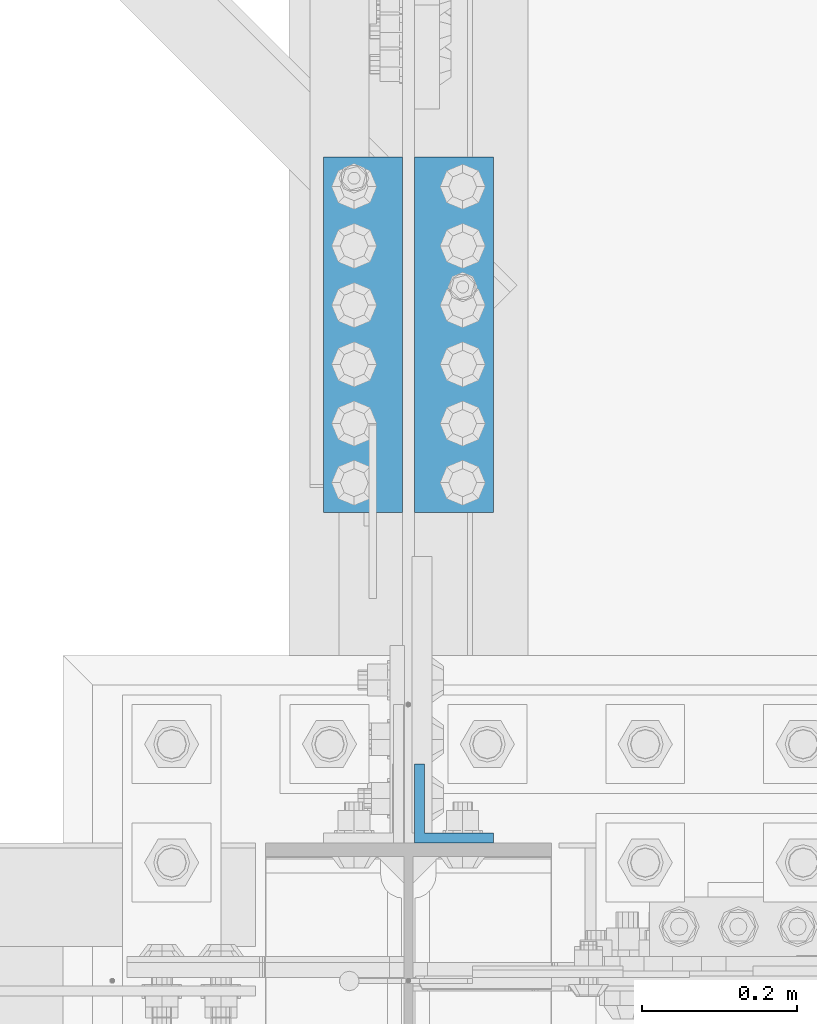
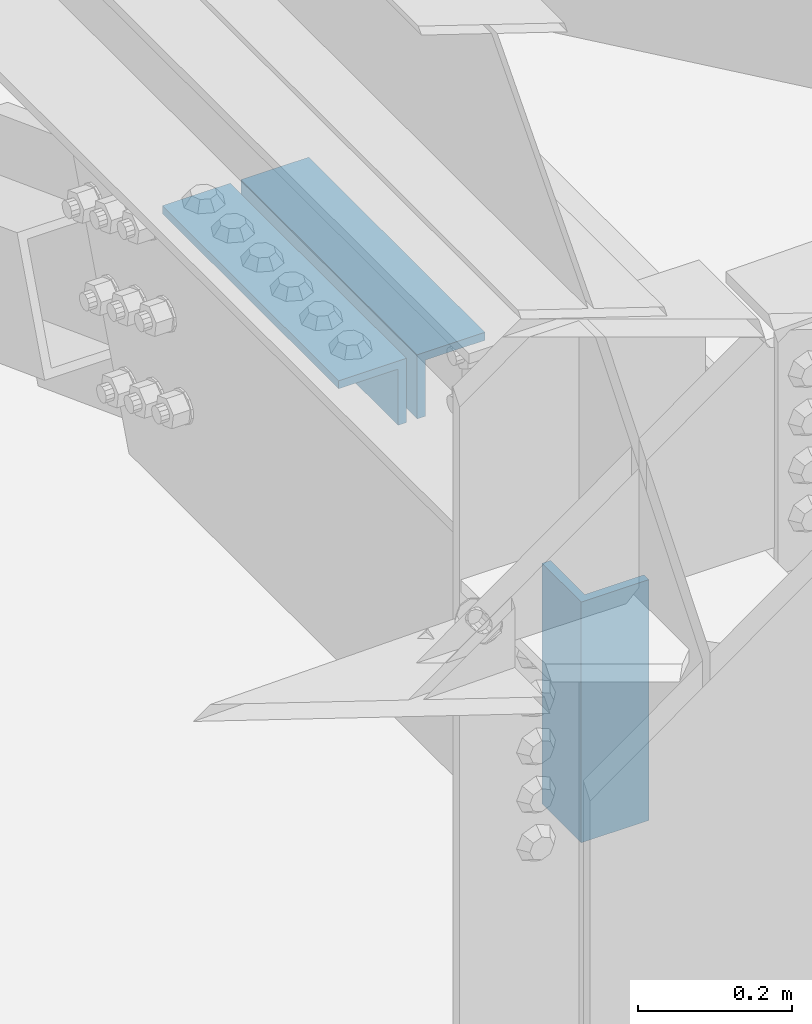
# One storey, part 2026 of 3843: 3 beams, 1 element without a shape of its own.
"""IFC2X3 building model written with IfcOpenShell, lengths in millimetres."""

from ifc_helpers import new_model, si_unit, frame, origin_with_axes, place, context, subcontext, project, spatial, faceted_brep, material, type_object, element, aggregate, save


model = new_model("IFC2X3")

# Units and contexts
model_context = context("Model", 3, precision=1e-05, world=origin_with_axes())
body_context = subcontext(model_context, "Body", "Model", "MODEL_VIEW")
ifc_project = project(units=[si_unit("LENGTHUNIT", "METRE", prefix="MILLI"), si_unit("AREAUNIT", "SQUARE_METRE"), si_unit("VOLUMEUNIT", "CUBIC_METRE"), si_unit("MASSUNIT", "GRAM", prefix="KILO"), si_unit("TIMEUNIT", "SECOND"), si_unit("PLANEANGLEUNIT", "RADIAN"), si_unit("SOLIDANGLEUNIT", "STERADIAN"), si_unit("THERMODYNAMICTEMPERATUREUNIT", "DEGREE_CELSIUS"), si_unit("LUMINOUSINTENSITYUNIT", "LUMEN")], contexts=[model_context])

# Site, building, storey
site_placement = place(None, origin_with_axes())
site = spatial("IfcSite", under=ifc_project, at=site_placement, CompositionType="ELEMENT")
building_placement = place(site_placement, origin_with_axes())
building = spatial("IfcBuilding", under=site, at=building_placement, Name="Undefined", CompositionType="ELEMENT")
storey_placement = place(building_placement, origin_with_axes())
storey = spatial("IfcBuildingStorey", under=building, at=storey_placement, Name="Undefined", CompositionType="ELEMENT", Elevation=0.0)

# Assembly, beams
assembly_placement = place(storey_placement, origin_with_axes())
assembly = element("IfcElementAssembly", 1, at=assembly_placement, inside=storey, Name="PLATE", AssemblyPlace="NOTDEFINED", PredefinedType="RIGID_FRAME")
ifc_material = material(Name="STEEL/A572-50")
beam_type = type_object("IfcBeamType", Name="L4X4X1/2", PredefinedType="NOTDEFINED")
beam_1_placement = place(assembly_placement, frame((42121.1375000002, 26676.3499999985, 45135.41335278), z_axis=(0.0, 0.0, -1.0), x_axis=(0.0, -1.0, 0.0)))
beam_1 = element("IfcBeam", 2, at=beam_1_placement, type_object=beam_type, material=ifc_material, Name="ANGLE", ObjectType="L4X4X1/2", context=body_context, shape_type="Brep", body=[
    faceted_brep([(0.0, 50.8000000000029, -50.8000000000029), (0.0, 50.8000000000029, 50.8000000000029), (457.199999999997, 50.8000000000029, 50.8000000000029), (457.199999999997, 50.8000000000029, -50.8000000000029), (0.0, 38.0999999999985, 50.8000000000029), (457.199999999997, 38.0999999999985, 50.8000000000029), (0.0, 38.0999999999985, -38.0999999999985), (457.199999999997, 38.0999999999985, -38.0999999999985), (0.0, -50.8000000000029, -38.1000000000058), (457.199999999997, -50.8000000000029, -38.0999999999985), (0.0, -50.8000000000029, -50.8000000000029), (457.199999999997, -50.8000000000029, -50.8000000000029)], [[[0, 1, 2, 3]], [[1, 4, 5, 2]], [[4, 6, 7, 5]], [[6, 8, 9, 7]], [[8, 10, 11, 9]], [[10, 0, 3, 11]], [[5, 7, 9, 11, 3, 2]], [[10, 8, 6, 4, 1, 0]]]),
])
beam_2_placement = place(assembly_placement, frame((42003.6625000002, 26219.1499999985, 45135.4133527767), z_axis=(0.0, 0.0, -1.0), x_axis=(0.0, 1.0, 0.0)))
beam_2 = element("IfcBeam", 3, at=beam_2_placement, type_object=beam_type, material=ifc_material, Name="ANGLE", ObjectType="L4X4X1/2", context=body_context, shape_type="Brep", body=[
    faceted_brep([(0.0, 50.8000000000029, -50.8000000000029), (0.0, 50.8000000000029, 50.8000000000029), (457.199999999997, 50.8000000000029, 50.8000000000029), (457.199999999997, 50.8000000000029, -50.8000000000029), (0.0, 38.0999999999985, 50.8000000000029), (457.199999999997, 38.0999999999985, 50.8000000000029), (0.0, 38.0999999999985, -38.0999999999985), (457.199999999997, 38.0999999999985, -38.0999999999985), (0.0, -50.8000000000029, -38.1000000000058), (457.199999999997, -50.8000000000029, -38.0999999999985), (0.0, -50.8000000000029, -50.8000000000029), (457.199999999997, -50.8000000000029, -50.8000000000029)], [[[0, 1, 2, 3]], [[1, 4, 5, 2]], [[4, 6, 7, 5]], [[6, 8, 9, 7]], [[8, 10, 11, 9]], [[10, 0, 3, 11]], [[5, 7, 9, 11, 3, 2]], [[10, 8, 6, 4, 1, 0]]]),
])
beam_3_placement = place(assembly_placement, frame((42121.1375000002, 25844.5000000011, 45052.8633527715), z_axis=(0.0, 1.0, 0.0), x_axis=(0.0, 0.0, -1.0)))
beam_3 = element("IfcBeam", 4, at=beam_3_placement, type_object=beam_type, material=ifc_material, Name="ANGLE", ObjectType="L4X4X1/2", context=body_context, shape_type="Brep", body=[
    faceted_brep([(0.0, 50.8000000000029, -50.8000000000029), (0.0, 50.8000000000029, 50.8000000000029), (381.0, 50.8000000000029, 50.8000000000029), (381.0, 50.8000000000029, -50.8000000000029), (0.0, 38.0999999999985, 50.8000000000029), (381.0, 38.0999999999985, 50.8000000000029), (0.0, 38.0999999999985, -38.0999999999985), (381.0, 38.0999999999985, -38.1000000000058), (0.0, -50.8000000000029, -38.1000000000058), (381.0, -50.8000000000029, -38.1000000000058), (0.0, -50.8000000000029, -50.8000000000029), (381.0, -50.8000000000029, -50.8000000000029)], [[[0, 1, 2, 3]], [[1, 4, 5, 2]], [[4, 6, 7, 5]], [[6, 8, 9, 7]], [[8, 10, 11, 9]], [[10, 0, 3, 11]], [[5, 7, 9, 11, 3, 2]], [[10, 8, 6, 4, 1, 0]]]),
])
aggregate(assembly, [beam_1, beam_2, beam_3])

save(model, "model.ifc")
